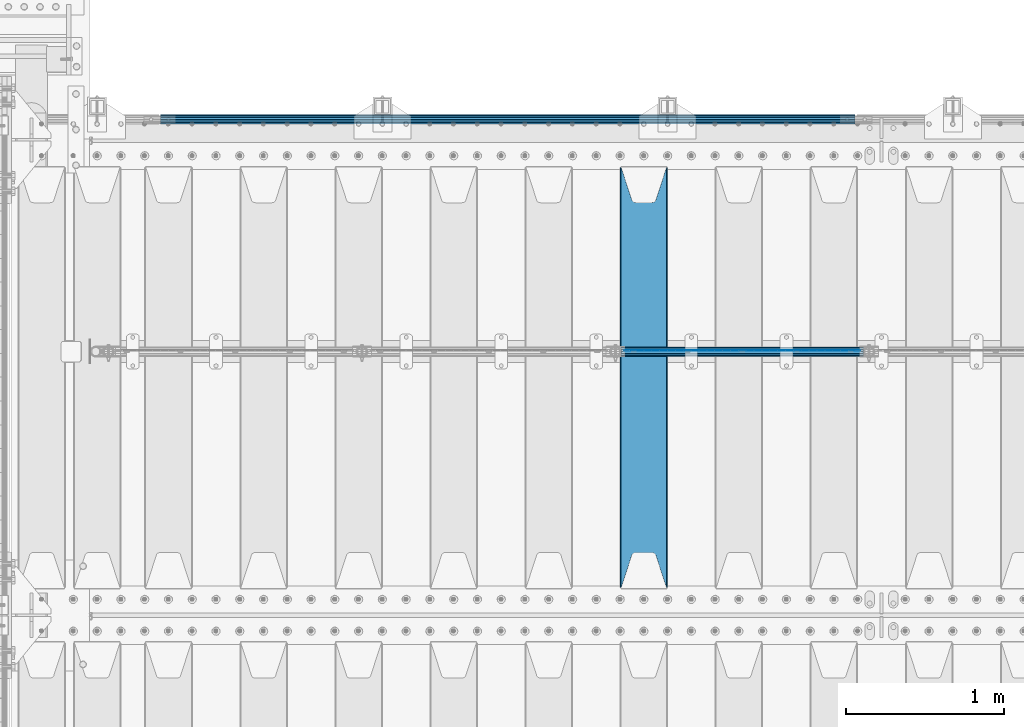
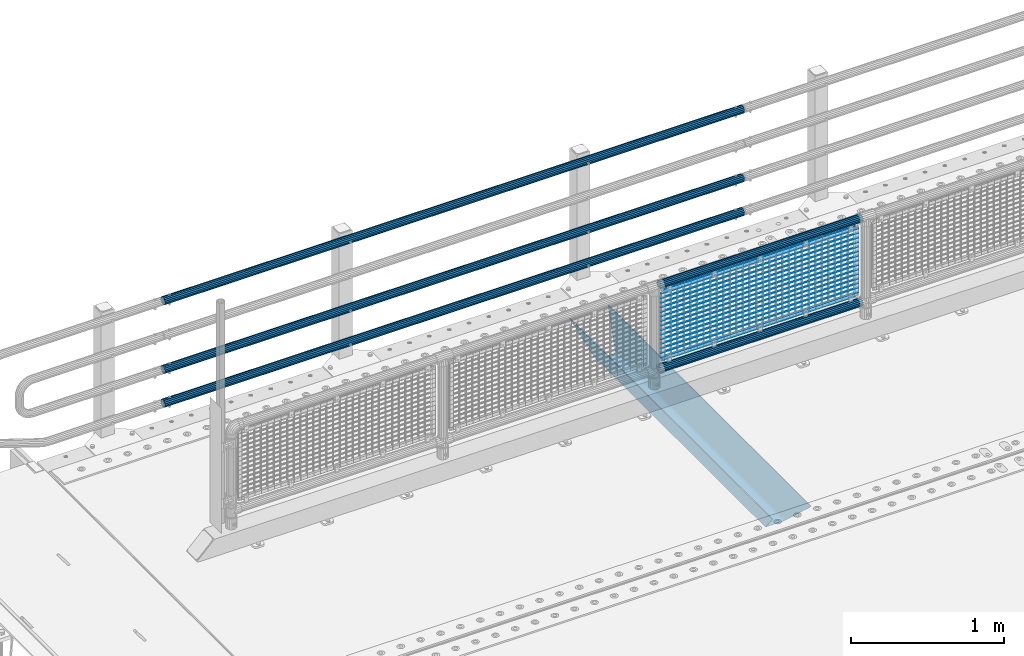
# One storey, part 122 of 247: 23 beams.
"""IFC2X3 building model written with IfcOpenShell, lengths in millimetres."""

import ifcopenshell
import ifcopenshell.guid

model = None  # the IFC model being written
_history = None  # IfcOwnerHistory: only IFC2X3 demands one
_inside = {}  # id of a spatial element -> (the spatial element, [elements in it])
_under = {}  # id of a project, library or spatial element -> (it, [spatial elements below it])
_declared = {}  # id of a project -> (the project, [libraries it declares])
_typed = {}  # id of a type object -> (the type object, [elements of that type])
_made_of = {}  # id of a material, layer set ... -> (it, [elements and type objects made of it])


def new_model(schema):
    """Start an empty IFC model of exactly this schema.

    Asked for "IFC4X3", IfcOpenShell would pick the latest addendum, in which some entities
    have other attributes; the version numbers below select the first issue.
    IFC2X3 requires an IfcOwnerHistory on every rooted entity: one is made here for all.
    """
    global model, _history
    if schema == "IFC4X3":
        model = ifcopenshell.file(schema_version=(4, 3, 0, 0))
    else:
        model = ifcopenshell.file(schema=schema)
    _inside.clear()
    _under.clear()
    _declared.clear()
    _typed.clear()
    _made_of.clear()
    _history = None
    if model.schema == "IFC2X3":
        org = make("IfcOrganization", Name="unknown")
        user = make(
            "IfcPersonAndOrganization",
            ThePerson=make("IfcPerson", FamilyName="unknown"),
            TheOrganization=org,
        )
        app = make(
            "IfcApplication",
            ApplicationDeveloper=org,
            Version="unknown",
            ApplicationFullName="unknown",
            ApplicationIdentifier="unknown",
        )
        _history = make(
            "IfcOwnerHistory",
            OwningUser=user,
            OwningApplication=app,
            ChangeAction="ADDED",
            CreationDate=0,
        )
    return model


def make(cls, **values):
    """One entity of the class cls with the attributes given. An attribute that is None is left unset."""
    return model.create_entity(
        cls, **{name: value for name, value in values.items() if value is not None}
    )


def rooted(cls, **values):
    """An entity with a GlobalId (a new one), such as an element, a storey or a relation."""
    return make(cls, GlobalId=ifcopenshell.guid.new(), OwnerHistory=_history, **values)


def si_unit(unit_type, name, prefix=None):
    """IfcSIUnit, for example si_unit("LENGTHUNIT", "METRE", prefix="MILLI")."""
    return make("IfcSIUnit", UnitType=unit_type, Prefix=prefix, Name=name)


def assignment(units):
    """IfcUnitAssignment: the units of a project."""
    return None if units is None else make("IfcUnitAssignment", Units=units)


def point(xyz):
    """IfcCartesianPoint."""
    return None if xyz is None else make("IfcCartesianPoint", Coordinates=xyz)


def direction(xyz):
    """IfcDirection."""
    return None if xyz is None else make("IfcDirection", DirectionRatios=xyz)


def frame(location, z_axis=None, x_axis=None):
    """IfcAxis2Placement3D, a coordinate frame: its origin and axes. An axis left out is left unset."""
    return make(
        "IfcAxis2Placement3D",
        Location=point(location),
        Axis=direction(z_axis),
        RefDirection=direction(x_axis),
    )


def origin_with_axes():
    """The frame at (0, 0, 0) with the z axis (0, 0, 1) and the x axis (1, 0, 0) written out."""
    return frame((0.0, 0.0, 0.0), z_axis=(0.0, 0.0, 1.0), x_axis=(1.0, 0.0, 0.0))


def place(relative_to, where):
    """IfcLocalPlacement: puts the frame where relative to a parent placement (None: the world)."""
    return make(
        "IfcLocalPlacement", PlacementRelTo=relative_to, RelativePlacement=where
    )


def context(
    kind, dimensions, precision=None, world=None, true_north=None, identifier=None
):
    """IfcGeometricRepresentationContext, for example the 3D "Model" context."""
    return make(
        "IfcGeometricRepresentationContext",
        ContextIdentifier=identifier,
        ContextType=kind,
        CoordinateSpaceDimension=dimensions,
        Precision=precision,
        WorldCoordinateSystem=world,
        TrueNorth=true_north,
    )


def subcontext(parent, identifier, kind, view, scale=None):
    """IfcGeometricRepresentationSubContext, for example "Body" below "Model"."""
    return make(
        "IfcGeometricRepresentationSubContext",
        ContextIdentifier=identifier,
        ContextType=kind,
        ParentContext=parent,
        TargetScale=scale,
        TargetView=view,
    )


def project(units=None, contexts=None):
    """IfcProject with its units and contexts."""
    return rooted(
        "IfcProject",
        Name="project",
        RepresentationContexts=contexts,
        UnitsInContext=assignment(units),
    )


def spatial(cls, under=None, at=None, **own):
    """A site, building, storey or space (cls), placed at a placement, below another one or the project."""
    s = rooted(cls, ObjectPlacement=at, **own)
    if under is not None:
        _under.setdefault(under.id(), (under, []))[1].append(s)
    return s


def faces_of(points, faces, orient=None, outer=None):
    """IfcFace entities. A face is a list of loops; a loop is a list of indices into points, from 0.

    orient and outer hold one flag for each loop. By default every Orientation is true, the
    first loop of a face is its IfcFaceOuterBound and the others are IfcFaceBound.
    """
    made = []
    for i, loops in enumerate(faces):
        bounds = []
        for j, loop in enumerate(loops):
            is_outer = j == 0 if outer is None else outer[i][j]
            bounds.append(
                make(
                    "IfcFaceOuterBound" if is_outer else "IfcFaceBound",
                    Bound=make("IfcPolyLoop", Polygon=[points[k] for k in loop]),
                    Orientation=True if orient is None else orient[i][j],
                )
            )
        made.append(make("IfcFace", Bounds=bounds))
    return made


def faceted_brep(points, faces, orient=None, outer=None, voids=None):
    """IfcFacetedBrep: a solid bounded by flat faces; with voids (closed shells), ...WithVoids."""
    shared = [point(p) for p in points]
    hull = make("IfcClosedShell", CfsFaces=faces_of(shared, faces, orient, outer))
    if voids is None:
        return make("IfcFacetedBrep", Outer=hull)
    return make(
        "IfcFacetedBrepWithVoids",
        Outer=hull,
        Voids=[
            make(cls, CfsFaces=faces_of(shared, fs, o, b)) for cls, fs, o, b in voids
        ],
    )


def shape(context_of_items, identifier, shape_type, items):
    """IfcShapeRepresentation: the items that make up one representation, for example the "Body"."""
    return make(
        "IfcShapeRepresentation",
        ContextOfItems=context_of_items,
        RepresentationIdentifier=identifier,
        RepresentationType=shape_type,
        Items=items,
    )


def material(Name=None, Category=None):
    """IfcMaterial."""
    return make("IfcMaterial", Name=Name, Category=Category)


def made_of(thing, what):
    """Note that an element or type object is made of a material, layer set ...; save() writes the relation."""
    if what is not None:
        _made_of.setdefault(what.id(), (what, []))[1].append(thing)
    return thing


def type_object(cls, material=None, **own):
    """A type object (cls), such as IfcWallType, which elements share."""
    return made_of(rooted(cls, **own), material)


def element(
    cls,
    number,
    at=None,
    inside=None,
    cuts=None,
    type_object=None,
    material=None,
    context=None,
    identifier="Body",
    shape_type=None,
    held_by="IfcProductDefinitionShape",
    body=None,
    shapes=None,
    **own,
):
    """One element of the class cls, such as IfcWall. Its Tag is "e" and its number.

    at: its placement. inside: the storey or other place that contains it. cuts: it is an
    opening in that element (IfcRelVoidsElement). A single representation is given by context,
    identifier, shape_type and body (its items); several are given by shapes. held_by: the class
    of the entity that holds the representations. save() writes the other relations.
    """
    e = rooted(cls, Tag="e%d" % number, ObjectPlacement=at, **own)
    if body is not None:
        shapes = [shape(context, identifier, shape_type, body)]
    if shapes is not None:
        e.Representation = make(held_by, Representations=shapes)
    if inside is not None:
        _inside.setdefault(inside.id(), (inside, []))[1].append(e)
    if cuts is not None:
        rooted(
            "IfcRelVoidsElement", RelatingBuildingElement=cuts, RelatedOpeningElement=e
        )
    if type_object is not None:
        _typed.setdefault(type_object.id(), (type_object, []))[1].append(e)
    return made_of(e, material)


def aggregate(whole, parts):
    """IfcRelAggregates: a whole, such as a stair, and the parts it consists of."""
    return rooted("IfcRelAggregates", RelatingObject=whole, RelatedObjects=parts)


def save(model, path):
    """Write the relations noted so far, then the file.

    IfcRelAggregates (storeys below a building ...), IfcRelContainedInSpatialStructure (elements
    in a storey), IfcRelDefinesByType, IfcRelAssociatesMaterial and IfcRelDeclares: one each for
    every whole, place, type object, material and project.
    """
    for whole, parts in _under.values():
        aggregate(whole, parts)
    for where, things in _inside.values():
        rooted(
            "IfcRelContainedInSpatialStructure",
            RelatedElements=things,
            RelatingStructure=where,
        )
    for kind, things in _typed.values():
        rooted("IfcRelDefinesByType", RelatedObjects=things, RelatingType=kind)
    for what, things in _made_of.values():
        rooted("IfcRelAssociatesMaterial", RelatedObjects=things, RelatingMaterial=what)
    for by, libraries in _declared.values():
        rooted("IfcRelDeclares", RelatingContext=by, RelatedDefinitions=libraries)
    model.write(path)


model = new_model("IFC2X3")

# Units and contexts
model_context = context("Model", 3, precision=1e-05, world=origin_with_axes())
body_context = subcontext(model_context, "Body", "Model", "MODEL_VIEW")
ifc_project = project(units=[si_unit("LENGTHUNIT", "METRE", prefix="MILLI"), si_unit("AREAUNIT", "SQUARE_METRE"), si_unit("VOLUMEUNIT", "CUBIC_METRE"), si_unit("MASSUNIT", "GRAM", prefix="KILO"), si_unit("TIMEUNIT", "SECOND"), si_unit("PLANEANGLEUNIT", "RADIAN"), si_unit("SOLIDANGLEUNIT", "STERADIAN"), si_unit("THERMODYNAMICTEMPERATUREUNIT", "DEGREE_CELSIUS"), si_unit("LUMINOUSINTENSITYUNIT", "LUMEN")], contexts=[model_context])

# Site, building, storey
site_placement = place(None, origin_with_axes())
site = spatial("IfcSite", under=ifc_project, at=site_placement, CompositionType="ELEMENT")
building_placement = place(site_placement, origin_with_axes())
building = spatial("IfcBuilding", under=site, at=building_placement, Name="Standard", CompositionType="ELEMENT")
storey_placement = place(building_placement, origin_with_axes())
storey = spatial("IfcBuildingStorey", under=building, at=storey_placement, Name="Undefined", CompositionType="ELEMENT", Elevation=0.0)

# Beams
ifc_material_1 = material(Name="STEEL/S355N")
beam_type_1 = type_object("IfcBeamType", PredefinedType="NOTDEFINED")
beam_1_placement = place(storey_placement, frame((4000.0, 6175.0, -115.0), z_axis=(0.0, 0.0, 1.0), x_axis=(0.0, 1.0, 0.0)))
element("IfcBeam", 1, at=beam_1_placement, inside=storey, type_object=beam_type_1, material=ifc_material_1, context=body_context, shape_type="Brep", body=[
    faceted_brep([(0.0, 150.0, 115.0), (0.0, 143.689999999999, 115.0), (2650.00000000297, 143.689999999999, 115.0), (2650.00000000297, 150.0, 115.0), (2650.00000000297, 142.059565218402, 110.0000000031), (2650.00000000297, 148.369565218403, 110.0000000031), (2441.90079219208, -80.1103600731112, -98.0992078077845), (2437.7588105432, -77.5672621345584, -102.241189456673), (2434.06523489746, -74.4080125315522, -105.934765102404), (2430.91086095089, -70.710272125576, -109.089139048974), (2428.37322971128, -66.5649389910068, -111.626770288588), (2426.51472138054, -62.0739139532889, -113.485278619323), (2425.38102192091, -57.3475956567672, -114.618978078955), (2424.99999999987, -52.5021667386536, -115.0), (2424.99999999987, 52.5021667386536, -115.0), (2425.38102192091, 57.3475956567672, -114.618978078955), (2426.51472138054, 62.0739139532889, -113.485278619323), (2428.37322971128, 66.5649389910068, -111.626770288588), (2430.91086095089, 70.710272125576, -109.089139048974), (2434.06523489746, 74.4080125315522, -105.934765102404), (2437.7588105432, 77.5672621345584, -102.241189456673), (2441.90079219208, 80.1103600731112, -98.0992078077846), (2446.38936140511, 81.9747917625791, -93.6106385947584), (2448.24948500409, 76.2713538057251, -91.7505149957729), (2444.62967112262, 74.76777986261, -95.3703288772456), (2441.28936334126, 72.7168944282894, -98.710636658607), (2438.31067330438, 70.1691124903846, -101.689326695487), (2435.76682334747, 67.1870637758839, -104.233176652398), (2433.72034654133, 63.8440531834895, -106.279653458539), (2432.22154950041, 60.222258798236, -107.778450499454), (2431.30727574265, 56.4107117849089, -108.692724257221), (2430.99999999987, 52.5031078186876, -109.0), (2430.99999999987, -52.5031078186876, -109.0), (2431.30727574265, -56.4107117849089, -108.692724257221), (2432.22154950041, -60.222258798236, -107.778450499454), (2433.72034654133, -63.8440531834895, -106.279653458539), (2435.76682334747, -67.1870637758839, -104.233176652398), (2438.31067330438, -70.1691124903846, -101.689326695487), (2441.28936334126, -72.7168944282894, -98.7106366586071), (2444.62967112262, -74.76777986261, -95.3703288772457), (2448.24948500409, -76.2713538057251, -91.7505149957729), (2650.00000000297, -142.059565218402, 110.0000000031), (2650.00000000297, -148.369565218403, 110.0000000031), (2446.38936140511, -81.9747917625791, -93.6106385947584), (2650.00000000297, -143.689999999999, 115.0), (2650.00000000297, -150.0, 115.0), (0.0, -143.689999999999, 115.0), (0.0, -150.0, 115.0), (0.0, -148.369565218261, 110.000000002663), (203.610638597422, -81.9747917625791, -93.6106385947584), (208.099207810448, -80.1103600731112, -98.0992078077845), (212.241189459336, -77.5672621345584, -102.241189456673), (215.934765105068, -74.4080125315522, -105.934765102404), (219.089139051637, -70.710272125576, -109.089139048974), (221.626770291251, -66.5649389910068, -111.626770288588), (223.485278621985, -62.0739139532889, -113.485278619323), (224.618978081617, -57.3475956567672, -114.618978078955), (225.000000002663, -52.5021667386536, -115.0), (225.000000002663, 52.5021667386536, -115.0), (224.618978081617, 57.3475956567672, -114.618978078955), (223.485278621985, 62.0739139532889, -113.485278619323), (221.626770291251, 66.5649389910068, -111.626770288588), (219.089139051637, 70.710272125576, -109.089139048974), (215.934765105068, 74.4080125315522, -105.934765102404), (212.241189459336, 77.5672621345584, -102.241189456673), (208.099207810448, 80.1103600731112, -98.0992078077846), (203.610638597422, 81.9747917625791, -93.6106385947584), (0.0, 148.369565218261, 110.000000002663), (0.0, 142.05956521826, 110.000000002663), (201.750514998436, 76.2713538057251, -91.7505149957729), (205.370328879908, 74.76777986261, -95.3703288772456), (208.710636661271, 72.7168944282894, -98.710636658607), (211.68932669815, 70.1691124903846, -101.689326695487), (214.233176655061, 67.1870637758839, -104.233176652398), (216.279653461202, 63.8440531834895, -106.279653458539), (217.778450502117, 60.222258798236, -107.778450499454), (218.692724259885, 56.4107117849089, -108.692724257221), (219.000000002663, 52.5031078186876, -109.0), (219.000000002663, -52.5031078186876, -109.0), (218.692724259885, -56.4107117849089, -108.692724257221), (217.778450502117, -60.222258798236, -107.778450499454), (216.279653461202, -63.8440531834895, -106.279653458539), (214.233176655061, -67.1870637758839, -104.233176652398), (211.68932669815, -70.1691124903846, -101.689326695487), (208.710636661271, -72.7168944282894, -98.7106366586071), (205.370328879908, -74.76777986261, -95.3703288772457), (201.750514998436, -76.2713538057251, -91.7505149957729), (0.0, -142.05956521826, 110.000000002663)], [[[0, 1, 2, 3]], [[3, 2, 4, 5]], [[6, 7, 8, 9, 10, 11, 12, 13, 14, 15, 16, 17, 18, 19, 20, 21, 22, 5, 4, 23, 24, 25, 26, 27, 28, 29, 30, 31, 32, 33, 34, 35, 36, 37, 38, 39, 40, 41, 42, 43]], [[44, 45, 42, 41]], [[46, 47, 45, 44]], [[43, 42, 45, 47, 48, 49]], [[6, 43, 49, 50]], [[7, 6, 50, 51]], [[8, 7, 51, 52]], [[9, 8, 52, 53]], [[10, 9, 53, 54]], [[11, 10, 54, 55]], [[12, 11, 55, 56]], [[13, 12, 56, 57]], [[14, 13, 57, 58]], [[15, 14, 58, 59]], [[16, 15, 59, 60]], [[17, 16, 60, 61]], [[18, 17, 61, 62]], [[19, 18, 62, 63]], [[20, 19, 63, 64]], [[21, 20, 64, 65]], [[22, 21, 65, 66]], [[0, 3, 5, 22, 66, 67]], [[1, 0, 67, 68]], [[23, 4, 2, 1, 68, 69]], [[24, 23, 69, 70]], [[25, 24, 70, 71]], [[26, 25, 71, 72]], [[27, 26, 72, 73]], [[28, 27, 73, 74]], [[29, 28, 74, 75]], [[30, 29, 75, 76]], [[31, 30, 76, 77]], [[32, 31, 77, 78]], [[33, 32, 78, 79]], [[34, 33, 79, 80]], [[35, 34, 80, 81]], [[36, 35, 81, 82]], [[37, 36, 82, 83]], [[38, 37, 83, 84]], [[39, 38, 84, 85]], [[40, 39, 85, 86]], [[46, 44, 41, 40, 86, 87]], [[47, 46, 87, 48]], [[86, 85, 84, 83, 82, 81, 80, 79, 78, 77, 76, 75, 74, 73, 72, 71, 70, 69, 68, 67, 66, 65, 64, 63, 62, 61, 60, 59, 58, 57, 56, 55, 54, 53, 52, 51, 50, 49, 48, 87]]]),
])
ifc_material_2 = material()
beam_type_2 = type_object("IfcBeamType", PredefinedType="NOTDEFINED")
beam_2_placement = place(storey_placement, frame((5333.99999999987, 9129.85000000009, 149.849999999725), z_axis=(0.0, 0.0, -1.0), x_axis=(-1.0, 0.0, 0.0)))
element("IfcBeam", 2, at=beam_2_placement, inside=storey, type_object=beam_type_2, material=ifc_material_2, context=body_context, shape_type="Brep", body=[
    faceted_brep([(0.0, -26.5499999999993, 0.0), (0.0, -24.5290015881747, 10.1602451292931), (4384.00249699992, -24.5290015881747, 10.1602451292931), (4384.00249699992, -26.5499999999993, 0.0), (0.0, -18.7736850405036, 18.7736850405028), (4384.00249699992, -18.7736850405036, 18.7736850405028), (0.0, -10.1602451292929, 24.5290015881747), (4384.00249699992, -10.1602451292929, 24.5290015881747), (0.0, 0.0, 26.55), (4384.00249699992, 0.0, 26.55), (0.0, 10.1602451292929, 24.5290015881747), (4384.00249699992, 10.1602451292929, 24.5290015881747), (0.0, 18.7736850405036, 18.7736850405028), (4384.00249699992, 18.7736850405036, 18.7736850405028), (0.0, 24.5290015881747, 10.1602451292931), (4384.00249699992, 24.5290015881747, 10.1602451292931), (0.0, 26.5499999999993, 0.0), (4384.00249699992, 26.5499999999993, 0.0), (0.0, 24.5290015881747, -10.1602451292931), (4384.00249699992, 24.5290015881747, -10.1602451292931), (0.0, 18.7736850405036, -18.7736850405028), (4384.00249699992, 18.7736850405036, -18.7736850405028), (0.0, 10.1602451292929, -24.5290015881747), (4384.00249699992, 10.1602451292929, -24.5290015881747), (0.0, 0.0, -26.55), (4384.00249699992, 0.0, -26.55), (0.0, -10.1602451292929, -24.5290015881747), (4384.00249699992, -10.1602451292929, -24.5290015881747), (0.0, -18.7736850405036, -18.7736850405028), (4384.00249699992, -18.7736850405036, -18.7736850405028), (0.0, -24.5290015881747, -10.1602451292931), (4384.00249699992, -24.5290015881747, -10.1602451292931), (0.0, -30.1499999999996, 0.0), (0.0, -27.8549679052148, -11.5379054858076), (4384.00249699992, -27.8549679052157, -11.5379054858075), (4384.00249699992, -30.1499999999996, 0.0), (0.0, -21.3192694527743, -21.3192694527752), (4384.00249699992, -21.3192694527752, -21.3192694527744), (0.0, -11.5379054858076, -27.8549679052157), (4384.00249699992, -11.5379054858076, -27.8549679052153), (0.0, 0.0, -30.1499999999996), (4384.00249699992, 0.0, -30.15), (0.0, 11.5379054858076, -27.8549679052157), (4384.00249699992, 11.5379054858076, -27.8549679052153), (0.0, 21.3192694527743, -21.3192694527752), (4384.00249699992, 21.3192694527752, -21.3192694527744), (0.0, 27.8549679052157, -11.5379054858076), (4384.00249699992, 27.8549679052157, -11.5379054858074), (0.0, 30.1499999999996, 0.0), (4384.00249699992, 30.1499999999996, 0.0), (0.0, 27.8549679052157, 11.5379054858076), (4384.00249699992, 27.8549679052157, 11.5379054858075), (0.0, 21.3192694527743, 21.3192694527752), (4384.00249699992, 21.3192694527752, 21.3192694527744), (0.0, 11.5379054858076, 27.8549679052157), (4384.00249699992, 11.5379054858076, 27.8549679052153), (0.0, 0.0, 30.1499999999996), (4384.00249699992, 0.0, 30.15), (0.0, -11.5379054858076, 27.8549679052157), (4384.00249699992, -11.5379054858076, 27.8549679052153), (0.0, -21.3192694527743, 21.3192694527752), (4384.00249699992, -21.3192694527752, 21.3192694527744), (0.0, -27.8549679052157, 11.5379054858076), (4384.00249699992, -27.8549679052157, 11.5379054858075)], [[[0, 1, 2, 3]], [[1, 4, 5, 2]], [[4, 6, 7, 5]], [[6, 8, 9, 7]], [[8, 10, 11, 9]], [[10, 12, 13, 11]], [[12, 14, 15, 13]], [[14, 16, 17, 15]], [[16, 18, 19, 17]], [[18, 20, 21, 19]], [[20, 22, 23, 21]], [[22, 24, 25, 23]], [[24, 26, 27, 25]], [[26, 28, 29, 27]], [[28, 30, 31, 29]], [[30, 0, 3, 31]], [[32, 33, 34, 35]], [[33, 36, 37, 34]], [[36, 38, 39, 37]], [[38, 40, 41, 39]], [[40, 42, 43, 41]], [[42, 44, 45, 43]], [[44, 46, 47, 45]], [[46, 48, 49, 47]], [[48, 50, 51, 49]], [[50, 52, 53, 51]], [[52, 54, 55, 53]], [[54, 56, 57, 55]], [[56, 58, 59, 57]], [[58, 60, 61, 59]], [[60, 62, 63, 61]], [[62, 32, 35, 63]], [[37, 39, 41, 43, 45, 47, 49, 51, 53, 55, 57, 59, 61, 63, 35, 34], [5, 7, 9, 11, 13, 15, 17, 19, 21, 23, 25, 27, 29, 31, 3, 2]], [[62, 60, 58, 56, 54, 52, 50, 48, 46, 44, 42, 40, 38, 36, 33, 32], [30, 28, 26, 24, 22, 20, 18, 16, 14, 12, 10, 8, 6, 4, 1, 0]]]),
])
beam_3_placement = place(storey_placement, frame((5333.99999999987, 9129.85000000009, 420.149999999728), z_axis=(0.0, 0.0, -1.0), x_axis=(-1.0, 0.0, 0.0)))
element("IfcBeam", 3, at=beam_3_placement, inside=storey, type_object=beam_type_2, material=ifc_material_2, context=body_context, shape_type="Brep", body=[
    faceted_brep([(0.0, -26.5499999999993, 0.0), (0.0, -24.5290015881747, 10.1602451292931), (4384.00249699992, -24.5290015881747, 10.1602451292931), (4384.00249699992, -26.5499999999993, 0.0), (0.0, -18.7736850405036, 18.7736850405028), (4384.00249699992, -18.7736850405036, 18.7736850405028), (0.0, -10.1602451292929, 24.5290015881747), (4384.00249699992, -10.1602451292929, 24.5290015881747), (0.0, 0.0, 26.55), (4384.00249699992, 0.0, 26.55), (0.0, 10.1602451292929, 24.5290015881747), (4384.00249699992, 10.1602451292929, 24.5290015881747), (0.0, 18.7736850405036, 18.7736850405028), (4384.00249699992, 18.7736850405036, 18.7736850405028), (0.0, 24.5290015881747, 10.1602451292931), (4384.00249699992, 24.5290015881747, 10.1602451292931), (0.0, 26.5499999999993, 0.0), (4384.00249699992, 26.5499999999993, 0.0), (0.0, 24.5290015881747, -10.1602451292931), (4384.00249699992, 24.5290015881747, -10.1602451292931), (0.0, 18.7736850405036, -18.7736850405028), (4384.00249699992, 18.7736850405036, -18.7736850405028), (0.0, 10.1602451292929, -24.5290015881747), (4384.00249699992, 10.1602451292929, -24.5290015881747), (0.0, 0.0, -26.55), (4384.00249699992, 0.0, -26.55), (0.0, -10.1602451292929, -24.5290015881747), (4384.00249699992, -10.1602451292929, -24.5290015881747), (0.0, -18.7736850405036, -18.7736850405028), (4384.00249699992, -18.7736850405036, -18.7736850405028), (0.0, -24.5290015881747, -10.1602451292931), (4384.00249699992, -24.5290015881747, -10.1602451292931), (0.0, -30.1499999999996, 0.0), (0.0, -27.8549679052148, -11.5379054858076), (4384.00249699992, -27.8549679052157, -11.5379054858075), (4384.00249699992, -30.1499999999996, 0.0), (0.0, -21.3192694527743, -21.3192694527752), (4384.00249699992, -21.3192694527752, -21.3192694527744), (0.0, -11.5379054858076, -27.8549679052157), (4384.00249699992, -11.5379054858076, -27.8549679052153), (0.0, 0.0, -30.1499999999996), (4384.00249699992, 0.0, -30.15), (0.0, 11.5379054858076, -27.8549679052157), (4384.00249699992, 11.5379054858076, -27.8549679052153), (0.0, 21.3192694527743, -21.3192694527752), (4384.00249699992, 21.3192694527752, -21.3192694527744), (0.0, 27.8549679052157, -11.5379054858076), (4384.00249699992, 27.8549679052157, -11.5379054858074), (0.0, 30.1499999999996, 0.0), (4384.00249699992, 30.1499999999996, 0.0), (0.0, 27.8549679052157, 11.5379054858076), (4384.00249699992, 27.8549679052157, 11.5379054858075), (0.0, 21.3192694527743, 21.3192694527752), (4384.00249699992, 21.3192694527752, 21.3192694527744), (0.0, 11.5379054858076, 27.8549679052157), (4384.00249699992, 11.5379054858076, 27.8549679052153), (0.0, 0.0, 30.1499999999996), (4384.00249699992, 0.0, 30.15), (0.0, -11.5379054858076, 27.8549679052157), (4384.00249699992, -11.5379054858076, 27.8549679052153), (0.0, -21.3192694527743, 21.3192694527752), (4384.00249699992, -21.3192694527752, 21.3192694527744), (0.0, -27.8549679052157, 11.5379054858076), (4384.00249699992, -27.8549679052157, 11.5379054858075)], [[[0, 1, 2, 3]], [[1, 4, 5, 2]], [[4, 6, 7, 5]], [[6, 8, 9, 7]], [[8, 10, 11, 9]], [[10, 12, 13, 11]], [[12, 14, 15, 13]], [[14, 16, 17, 15]], [[16, 18, 19, 17]], [[18, 20, 21, 19]], [[20, 22, 23, 21]], [[22, 24, 25, 23]], [[24, 26, 27, 25]], [[26, 28, 29, 27]], [[28, 30, 31, 29]], [[30, 0, 3, 31]], [[32, 33, 34, 35]], [[33, 36, 37, 34]], [[36, 38, 39, 37]], [[38, 40, 41, 39]], [[40, 42, 43, 41]], [[42, 44, 45, 43]], [[44, 46, 47, 45]], [[46, 48, 49, 47]], [[48, 50, 51, 49]], [[50, 52, 53, 51]], [[52, 54, 55, 53]], [[54, 56, 57, 55]], [[56, 58, 59, 57]], [[58, 60, 61, 59]], [[60, 62, 63, 61]], [[62, 32, 35, 63]], [[37, 39, 41, 43, 45, 47, 49, 51, 53, 55, 57, 59, 61, 63, 35, 34], [5, 7, 9, 11, 13, 15, 17, 19, 21, 23, 25, 27, 29, 31, 3, 2]], [[62, 60, 58, 56, 54, 52, 50, 48, 46, 44, 42, 40, 38, 36, 33, 32], [30, 28, 26, 24, 22, 20, 18, 16, 14, 12, 10, 8, 6, 4, 1, 0]]]),
])
beam_4_placement = place(storey_placement, frame((5333.99999999987, 9129.85000000009, 969.849999999725), z_axis=(0.0, 0.0, -1.0), x_axis=(-1.0, 0.0, 0.0)))
element("IfcBeam", 4, at=beam_4_placement, inside=storey, type_object=beam_type_2, material=ifc_material_2, context=body_context, shape_type="Brep", body=[
    faceted_brep([(0.0, -26.5499999999993, 0.0), (0.0, -24.5290015881747, 10.1602451292931), (4384.00249699992, -24.5290015881747, 10.1602451292931), (4384.00249699992, -26.5499999999993, 0.0), (0.0, -18.7736850405036, 18.7736850405028), (4384.00249699992, -18.7736850405036, 18.7736850405028), (0.0, -10.1602451292929, 24.5290015881747), (4384.00249699992, -10.1602451292929, 24.5290015881747), (0.0, 0.0, 26.55), (4384.00249699992, 0.0, 26.55), (0.0, 10.1602451292929, 24.5290015881747), (4384.00249699992, 10.1602451292929, 24.5290015881747), (0.0, 18.7736850405036, 18.7736850405028), (4384.00249699992, 18.7736850405036, 18.7736850405028), (0.0, 24.5290015881747, 10.1602451292931), (4384.00249699992, 24.5290015881747, 10.1602451292931), (0.0, 26.5499999999993, 0.0), (4384.00249699992, 26.5499999999993, 0.0), (0.0, 24.5290015881747, -10.1602451292931), (4384.00249699992, 24.5290015881747, -10.1602451292931), (0.0, 18.7736850405036, -18.7736850405028), (4384.00249699992, 18.7736850405036, -18.7736850405028), (0.0, 10.1602451292929, -24.5290015881747), (4384.00249699992, 10.1602451292929, -24.5290015881747), (0.0, 0.0, -26.55), (4384.00249699992, 0.0, -26.55), (0.0, -10.1602451292929, -24.5290015881747), (4384.00249699992, -10.1602451292929, -24.5290015881747), (0.0, -18.7736850405036, -18.7736850405028), (4384.00249699992, -18.7736850405036, -18.7736850405028), (0.0, -24.5290015881747, -10.1602451292931), (4384.00249699992, -24.5290015881747, -10.1602451292931), (0.0, -30.1499999999996, 0.0), (0.0, -27.8549679052148, -11.5379054858076), (4384.00249699992, -27.8549679052157, -11.5379054858075), (4384.00249699992, -30.1499999999996, 0.0), (0.0, -21.3192694527743, -21.3192694527752), (4384.00249699992, -21.3192694527752, -21.3192694527744), (0.0, -11.5379054858076, -27.8549679052157), (4384.00249699992, -11.5379054858076, -27.8549679052153), (0.0, 0.0, -30.1499999999996), (4384.00249699992, 0.0, -30.15), (0.0, 11.5379054858076, -27.8549679052157), (4384.00249699992, 11.5379054858076, -27.8549679052153), (0.0, 21.3192694527743, -21.3192694527752), (4384.00249699992, 21.3192694527752, -21.3192694527744), (0.0, 27.8549679052157, -11.5379054858076), (4384.00249699992, 27.8549679052157, -11.5379054858074), (0.0, 30.1499999999996, 0.0), (4384.00249699992, 30.1499999999996, 0.0), (0.0, 27.8549679052157, 11.5379054858076), (4384.00249699992, 27.8549679052157, 11.5379054858075), (0.0, 21.3192694527743, 21.3192694527752), (4384.00249699992, 21.3192694527752, 21.3192694527744), (0.0, 11.5379054858076, 27.8549679052157), (4384.00249699992, 11.5379054858076, 27.8549679052153), (0.0, 0.0, 30.1499999999996), (4384.00249699992, 0.0, 30.15), (0.0, -11.5379054858076, 27.8549679052157), (4384.00249699992, -11.5379054858076, 27.8549679052153), (0.0, -21.3192694527743, 21.3192694527752), (4384.00249699992, -21.3192694527752, 21.3192694527744), (0.0, -27.8549679052157, 11.5379054858076), (4384.00249699992, -27.8549679052157, 11.5379054858075)], [[[0, 1, 2, 3]], [[1, 4, 5, 2]], [[4, 6, 7, 5]], [[6, 8, 9, 7]], [[8, 10, 11, 9]], [[10, 12, 13, 11]], [[12, 14, 15, 13]], [[14, 16, 17, 15]], [[16, 18, 19, 17]], [[18, 20, 21, 19]], [[20, 22, 23, 21]], [[22, 24, 25, 23]], [[24, 26, 27, 25]], [[26, 28, 29, 27]], [[28, 30, 31, 29]], [[30, 0, 3, 31]], [[32, 33, 34, 35]], [[33, 36, 37, 34]], [[36, 38, 39, 37]], [[38, 40, 41, 39]], [[40, 42, 43, 41]], [[42, 44, 45, 43]], [[44, 46, 47, 45]], [[46, 48, 49, 47]], [[48, 50, 51, 49]], [[50, 52, 53, 51]], [[52, 54, 55, 53]], [[54, 56, 57, 55]], [[56, 58, 59, 57]], [[58, 60, 61, 59]], [[60, 62, 63, 61]], [[62, 32, 35, 63]], [[37, 39, 41, 43, 45, 47, 49, 51, 53, 55, 57, 59, 61, 63, 35, 34], [5, 7, 9, 11, 13, 15, 17, 19, 21, 23, 25, 27, 29, 31, 3, 2]], [[62, 60, 58, 56, 54, 52, 50, 48, 46, 44, 42, 40, 38, 36, 33, 32], [30, 28, 26, 24, 22, 20, 18, 16, 14, 12, 10, 8, 6, 4, 1, 0]]]),
])
beam_type_3 = type_object("IfcBeamType", PredefinedType="NOTDEFINED")
beam_5_placement = place(storey_placement, frame((3855.85000000001, 7664.5, 298.170000000002), z_axis=(0.0, 0.0, 1.0), x_axis=(1.0, 0.0, 0.0)))
element("IfcBeam", 5, at=beam_5_placement, inside=storey, type_object=beam_type_3, material=ifc_material_2, context=body_context, shape_type="Brep", body=[
    faceted_brep([(0.0, -25.3500000000004, 0.0), (0.0, -23.4203461491616, 9.70102501045585), (1530.0, -23.4203461491616, 9.70102501045506), (1530.0, -25.3500000000004, 0.0), (0.0, -17.9251569030794, 17.9251569030785), (1530.0, -17.9251569030794, 17.925156903079), (0.0, -9.70102501045494, 23.4203461491616), (1530.0, -9.70102501045494, 23.4203461491611), (0.0, 0.0, 25.3500000000004), (1530.0, 0.0, 25.35), (0.0, 9.70102501045494, 23.4203461491616), (1530.0, 9.70102501045494, 23.4203461491611), (0.0, 17.9251569030794, 17.9251569030785), (1530.0, 17.9251569030794, 17.925156903079), (0.0, 23.4203461491616, 9.70102501045585), (1530.0, 23.4203461491616, 9.70102501045506), (0.0, 25.3500000000004, 0.0), (1530.0, 25.3500000000004, 0.0), (0.0, 23.4203461491616, -9.70102501045585), (1530.0, 23.4203461491616, -9.70102501045506), (0.0, 17.9251569030794, -17.9251569030785), (1530.0, 17.9251569030794, -17.925156903079), (0.0, 9.70102501045494, -23.4203461491616), (1530.0, 9.70102501045494, -23.4203461491611), (0.0, 0.0, -25.3500000000004), (1530.0, 0.0, -25.35), (0.0, -9.70102501045494, -23.4203461491616), (1530.0, -9.70102501045494, -23.4203461491611), (0.0, -17.9251569030794, -17.9251569030785), (1530.0, -17.9251569030794, -17.925156903079), (0.0, -23.4203461491616, -9.70102501045585), (1530.0, -23.4203461491616, -9.70102501045506), (0.0, -30.1499999999996, 0.0), (0.0, -27.8549679052148, -11.5379054858076), (1530.0, -27.8549679052148, -11.5379054858075), (1530.0, -30.1499999999996, 0.0), (0.0, -21.3192694527743, -21.3192694527752), (1530.0, -21.3192694527743, -21.3192694527744), (0.0, -11.5379054858076, -27.8549679052157), (1530.0, -11.5379054858076, -27.8549679052153), (0.0, 0.0, -30.1499999999996), (1530.0, 0.0, -30.15), (0.0, 11.5379054858076, -27.8549679052157), (1530.0, 11.5379054858076, -27.8549679052153), (0.0, 21.3192694527743, -21.3192694527752), (1530.0, 21.3192694527743, -21.3192694527744), (0.0, 27.8549679052157, -11.5379054858076), (1530.0, 27.8549679052157, -11.5379054858074), (0.0, 30.1499999999996, 0.0), (1530.0, 30.1499999999996, 0.0), (0.0, 27.8549679052157, 11.5379054858076), (1530.0, 27.8549679052157, 11.5379054858074), (0.0, 21.3192694527743, 21.3192694527752), (1530.0, 21.3192694527743, 21.3192694527744), (0.0, 11.5379054858076, 27.8549679052157), (1530.0, 11.5379054858076, 27.8549679052153), (0.0, 0.0, 30.1499999999996), (1530.0, 0.0, 30.15), (0.0, -11.5379054858076, 27.8549679052157), (1530.0, -11.5379054858076, 27.8549679052153), (0.0, -21.3192694527743, 21.3192694527752), (1530.0, -21.3192694527743, 21.3192694527744), (0.0, -27.8549679052157, 11.5379054858076), (1530.0, -27.8549679052157, 11.5379054858074)], [[[0, 1, 2, 3]], [[1, 4, 5, 2]], [[4, 6, 7, 5]], [[6, 8, 9, 7]], [[8, 10, 11, 9]], [[10, 12, 13, 11]], [[12, 14, 15, 13]], [[14, 16, 17, 15]], [[16, 18, 19, 17]], [[18, 20, 21, 19]], [[20, 22, 23, 21]], [[22, 24, 25, 23]], [[24, 26, 27, 25]], [[26, 28, 29, 27]], [[28, 30, 31, 29]], [[30, 0, 3, 31]], [[32, 33, 34, 35]], [[33, 36, 37, 34]], [[36, 38, 39, 37]], [[38, 40, 41, 39]], [[40, 42, 43, 41]], [[42, 44, 45, 43]], [[44, 46, 47, 45]], [[46, 48, 49, 47]], [[48, 50, 51, 49]], [[50, 52, 53, 51]], [[52, 54, 55, 53]], [[54, 56, 57, 55]], [[56, 58, 59, 57]], [[58, 60, 61, 59]], [[60, 62, 63, 61]], [[62, 32, 35, 63]], [[37, 39, 41, 43, 45, 47, 49, 51, 53, 55, 57, 59, 61, 63, 35, 34], [5, 7, 9, 11, 13, 15, 17, 19, 21, 23, 25, 27, 29, 31, 3, 2]], [[62, 60, 58, 56, 54, 52, 50, 48, 46, 44, 42, 40, 38, 36, 33, 32], [30, 28, 26, 24, 22, 20, 18, 16, 14, 12, 10, 8, 6, 4, 1, 0]]]),
])
beam_6_placement = place(storey_placement, frame((3855.85, 7664.5, 969.85), z_axis=(0.0, 0.0, 1.0), x_axis=(1.0, 0.0, 0.0)))
element("IfcBeam", 6, at=beam_6_placement, inside=storey, type_object=beam_type_3, material=ifc_material_2, context=body_context, shape_type="Brep", body=[
    faceted_brep([(0.0, -25.3500000000004, 0.0), (0.0, -23.4203461491616, 9.70102501045585), (1530.0, -23.4203461491616, 9.70102501045506), (1530.0, -25.3500000000004, 0.0), (0.0, -17.9251569030794, 17.9251569030785), (1530.0, -17.9251569030794, 17.925156903079), (0.0, -9.70102501045494, 23.4203461491616), (1530.0, -9.70102501045494, 23.4203461491611), (0.0, 0.0, 25.3500000000004), (1530.0, 0.0, 25.35), (0.0, 9.70102501045494, 23.4203461491616), (1530.0, 9.70102501045494, 23.4203461491611), (0.0, 17.9251569030794, 17.9251569030785), (1530.0, 17.9251569030794, 17.925156903079), (0.0, 23.4203461491616, 9.70102501045585), (1530.0, 23.4203461491616, 9.70102501045506), (0.0, 25.3500000000004, 0.0), (1530.0, 25.3500000000004, 0.0), (0.0, 23.4203461491616, -9.70102501045585), (1530.0, 23.4203461491616, -9.70102501045506), (0.0, 17.9251569030794, -17.9251569030785), (1530.0, 17.9251569030794, -17.925156903079), (0.0, 9.70102501045494, -23.4203461491616), (1530.0, 9.70102501045494, -23.4203461491611), (0.0, 0.0, -25.3500000000004), (1530.0, 0.0, -25.35), (0.0, -9.70102501045494, -23.4203461491616), (1530.0, -9.70102501045494, -23.4203461491611), (0.0, -17.9251569030794, -17.9251569030785), (1530.0, -17.9251569030794, -17.925156903079), (0.0, -23.4203461491616, -9.70102501045585), (1530.0, -23.4203461491616, -9.70102501045506), (0.0, -30.1499999999996, 0.0), (0.0, -27.8549679052148, -11.5379054858076), (1530.0, -27.8549679052148, -11.5379054858075), (1530.0, -30.1499999999996, 0.0), (0.0, -21.3192694527743, -21.3192694527752), (1530.0, -21.3192694527743, -21.3192694527744), (0.0, -11.5379054858076, -27.8549679052157), (1530.0, -11.5379054858076, -27.8549679052153), (0.0, 0.0, -30.1499999999996), (1530.0, 0.0, -30.15), (0.0, 11.5379054858076, -27.8549679052157), (1530.0, 11.5379054858076, -27.8549679052153), (0.0, 21.3192694527743, -21.3192694527752), (1530.0, 21.3192694527743, -21.3192694527744), (0.0, 27.8549679052157, -11.5379054858076), (1530.0, 27.8549679052157, -11.5379054858074), (0.0, 30.1499999999996, 0.0), (1530.0, 30.1499999999996, 0.0), (0.0, 27.8549679052157, 11.5379054858076), (1530.0, 27.8549679052157, 11.5379054858074), (0.0, 21.3192694527743, 21.3192694527752), (1530.0, 21.3192694527743, 21.3192694527744), (0.0, 11.5379054858076, 27.8549679052157), (1530.0, 11.5379054858076, 27.8549679052153), (0.0, 0.0, 30.1499999999996), (1530.0, 0.0, 30.15), (0.0, -11.5379054858076, 27.8549679052157), (1530.0, -11.5379054858076, 27.8549679052153), (0.0, -21.3192694527743, 21.3192694527752), (1530.0, -21.3192694527743, 21.3192694527744), (0.0, -27.8549679052157, 11.5379054858076), (1530.0, -27.8549679052157, 11.5379054858074)], [[[0, 1, 2, 3]], [[1, 4, 5, 2]], [[4, 6, 7, 5]], [[6, 8, 9, 7]], [[8, 10, 11, 9]], [[10, 12, 13, 11]], [[12, 14, 15, 13]], [[14, 16, 17, 15]], [[16, 18, 19, 17]], [[18, 20, 21, 19]], [[20, 22, 23, 21]], [[22, 24, 25, 23]], [[24, 26, 27, 25]], [[26, 28, 29, 27]], [[28, 30, 31, 29]], [[30, 0, 3, 31]], [[32, 33, 34, 35]], [[33, 36, 37, 34]], [[36, 38, 39, 37]], [[38, 40, 41, 39]], [[40, 42, 43, 41]], [[42, 44, 45, 43]], [[44, 46, 47, 45]], [[46, 48, 49, 47]], [[48, 50, 51, 49]], [[50, 52, 53, 51]], [[52, 54, 55, 53]], [[54, 56, 57, 55]], [[56, 58, 59, 57]], [[58, 60, 61, 59]], [[60, 62, 63, 61]], [[62, 32, 35, 63]], [[37, 39, 41, 43, 45, 47, 49, 51, 53, 55, 57, 59, 61, 63, 35, 34], [5, 7, 9, 11, 13, 15, 17, 19, 21, 23, 25, 27, 29, 31, 3, 2]], [[62, 60, 58, 56, 54, 52, 50, 48, 46, 44, 42, 40, 38, 36, 33, 32], [30, 28, 26, 24, 22, 20, 18, 16, 14, 12, 10, 8, 6, 4, 1, 0]]]),
])
ifc_material_3 = material(Name="Misc_Undefined")
beam_type_4 = type_object("IfcBeamType", Name="D3", PredefinedType="NOTDEFINED")
for number, where, z_axis, x_axis in (
    (7, (3876.0, 7670.5, 851.597), (0.0, 0.0, 1.0), (1.0, 0.0, 0.0)),
    (8, (3876.0, 7670.5, 669.452), (0.0, 0.0, 1.0), (1.0, 0.0, 0.0)),
    (9, (3876.0, 7670.5, 523.736), (0.0, 0.0, 1.0), (1.0, 0.0, 0.0)),
    (10, (3876.0, 7670.5, 487.307), (0.0, 0.0, 1.0), (1.0, 0.0, 0.0)),
    (11, (3876.0, 7670.5, 705.881), (0.0, 0.0, 1.0), (1.0, 0.0, 0.0)),
    (12, (3876.0, 7670.5, 596.594000000001), (0.0, 0.0, 1.0), (1.0, 0.0, 0.0)),
    (13, (3876.0, 7670.5, 450.878), (0.0, 0.0, 1.0), (1.0, 0.0, 0.0)),
    (14, (3876.0, 7670.5, 815.168), (0.0, 0.0, 1.0), (1.0, 0.0, 0.0)),
    (15, (3876.0, 7670.5, 888.026), (0.0, 0.0, 1.0), (1.0, 0.0, 0.0)),
    (16, (3876.0, 7670.5, 778.739), (0.0, 0.0, 1.0), (1.0, 0.0, 0.0)),
    (17, (3876.0, 7670.5, 742.31), (0.0, 0.0, 1.0), (1.0, 0.0, 0.0)),
    (18, (3876.0, 7670.5, 633.023), (0.0, 0.0, 1.0), (1.0, 0.0, 0.0)),
    (19, (3876.0, 7670.5, 560.165), (0.0, 0.0, 1.0), (1.0, 0.0, 0.0)),
    (20, (3876.0, 7670.5, 414.449), (0.0, 0.0, 1.0), (1.0, 0.0, 0.0)),
):
    element("IfcBeam", number, at=place(storey_placement, frame(where, z_axis=z_axis, x_axis=x_axis)), inside=storey, type_object=beam_type_4, material=ifc_material_3, ObjectType="D3", context=body_context, shape_type="Brep", body=[
        faceted_brep([(1.81898940354586e-12, -1.5, -5.6843418860808e-14), (0.0, -0.75, -1.29903810567703), (1490.0, -0.75, -1.29903810567669), (1490.0, -1.5, 0.0), (0.0, 0.75, -1.29903810567703), (1490.0, 0.75, -1.29903810567669), (1.81898940354586e-12, 1.5, -5.6843418860808e-14), (1490.0, 1.5, 0.0), (0.0, 0.75, 1.29903810567703), (1490.0, 0.75, 1.29903810567669), (0.0, -0.75, 1.29903810567703), (1490.0, -0.75, 1.29903810567669)], [[[0, 1, 2, 3]], [[1, 4, 5, 2]], [[4, 6, 7, 5]], [[6, 8, 9, 7]], [[8, 10, 11, 9]], [[10, 0, 3, 11]], [[5, 7, 9, 11, 3, 2]], [[10, 8, 6, 4, 1, 0]]]),
    ])
beam_7_placement = place(storey_placement, frame((3901.0, 7670.5, 353.02), z_axis=(0.0, 0.0, 1.0), x_axis=(1.0, 0.0, 0.0)))
element("IfcBeam", 21, at=beam_7_placement, inside=storey, type_object=beam_type_4, material=ifc_material_3, ObjectType="D3", context=body_context, shape_type="Brep", body=[
    faceted_brep([(1.81898940354586e-12, -1.5, -5.6843418860808e-14), (0.0, -0.75, -1.29903810567703), (1440.0, -0.75, -1.29903810567669), (1440.0, -1.5, 0.0), (0.0, 0.75, -1.29903810567703), (1440.0, 0.75, -1.29903810567663), (1.81898940354586e-12, 1.5, -5.6843418860808e-14), (1440.0, 1.5, 0.0), (0.0, 0.75, 1.29903810567703), (1440.0, 0.75, 1.29903810567669), (0.0, -0.75, 1.29903810567703), (1440.0, -0.75, 1.29903810567669)], [[[0, 1, 2, 3]], [[1, 4, 5, 2]], [[4, 6, 7, 5]], [[6, 8, 9, 7]], [[8, 10, 11, 9]], [[10, 0, 3, 11]], [[5, 7, 9, 11, 3, 2]], [[10, 8, 6, 4, 1, 0]]]),
])
beam_8_placement = place(storey_placement, frame((3876.0, 7670.5, 378.02), z_axis=(0.0, 0.0, 1.0), x_axis=(1.0, 0.0, 0.0)))
element("IfcBeam", 22, at=beam_8_placement, inside=storey, type_object=beam_type_4, material=ifc_material_3, ObjectType="D3", context=body_context, shape_type="Brep", body=[
    faceted_brep([(1.81898940354586e-12, -1.5, -5.6843418860808e-14), (0.0, -0.75, -1.29903810567703), (1490.0, -0.75, -1.29903810567669), (1490.0, -1.5, 0.0), (0.0, 0.75, -1.29903810567703), (1490.0, 0.75, -1.29903810567669), (1.81898940354586e-12, 1.5, -5.6843418860808e-14), (1490.0, 1.5, 0.0), (0.0, 0.75, 1.29903810567703), (1490.0, 0.75, 1.29903810567669), (0.0, -0.75, 1.29903810567703), (1490.0, -0.75, 1.29903810567669)], [[[0, 1, 2, 3]], [[1, 4, 5, 2]], [[4, 6, 7, 5]], [[6, 8, 9, 7]], [[8, 10, 11, 9]], [[10, 0, 3, 11]], [[5, 7, 9, 11, 3, 2]], [[10, 8, 6, 4, 1, 0]]]),
])
beam_9_placement = place(storey_placement, frame((3901.0, 7670.5, 913.02), z_axis=(0.0, 0.0, 1.0), x_axis=(1.0, 0.0, 0.0)))
element("IfcBeam", 23, at=beam_9_placement, inside=storey, type_object=beam_type_4, material=ifc_material_3, ObjectType="D3", context=body_context, shape_type="Brep", body=[
    faceted_brep([(1.81898940354586e-12, -1.5, -5.6843418860808e-14), (0.0, -0.75, -1.29903810567703), (1440.0, -0.75, -1.29903810567669), (1440.0, -1.5, 0.0), (0.0, 0.75, -1.29903810567703), (1440.0, 0.75, -1.29903810567663), (1.81898940354586e-12, 1.5, -5.6843418860808e-14), (1440.0, 1.5, 0.0), (0.0, 0.75, 1.29903810567703), (1440.0, 0.75, 1.29903810567669), (0.0, -0.75, 1.29903810567703), (1440.0, -0.75, 1.29903810567669)], [[[0, 1, 2, 3]], [[1, 4, 5, 2]], [[4, 6, 7, 5]], [[6, 8, 9, 7]], [[8, 10, 11, 9]], [[10, 0, 3, 11]], [[5, 7, 9, 11, 3, 2]], [[10, 8, 6, 4, 1, 0]]]),
])

save(model, "model.ifc")
